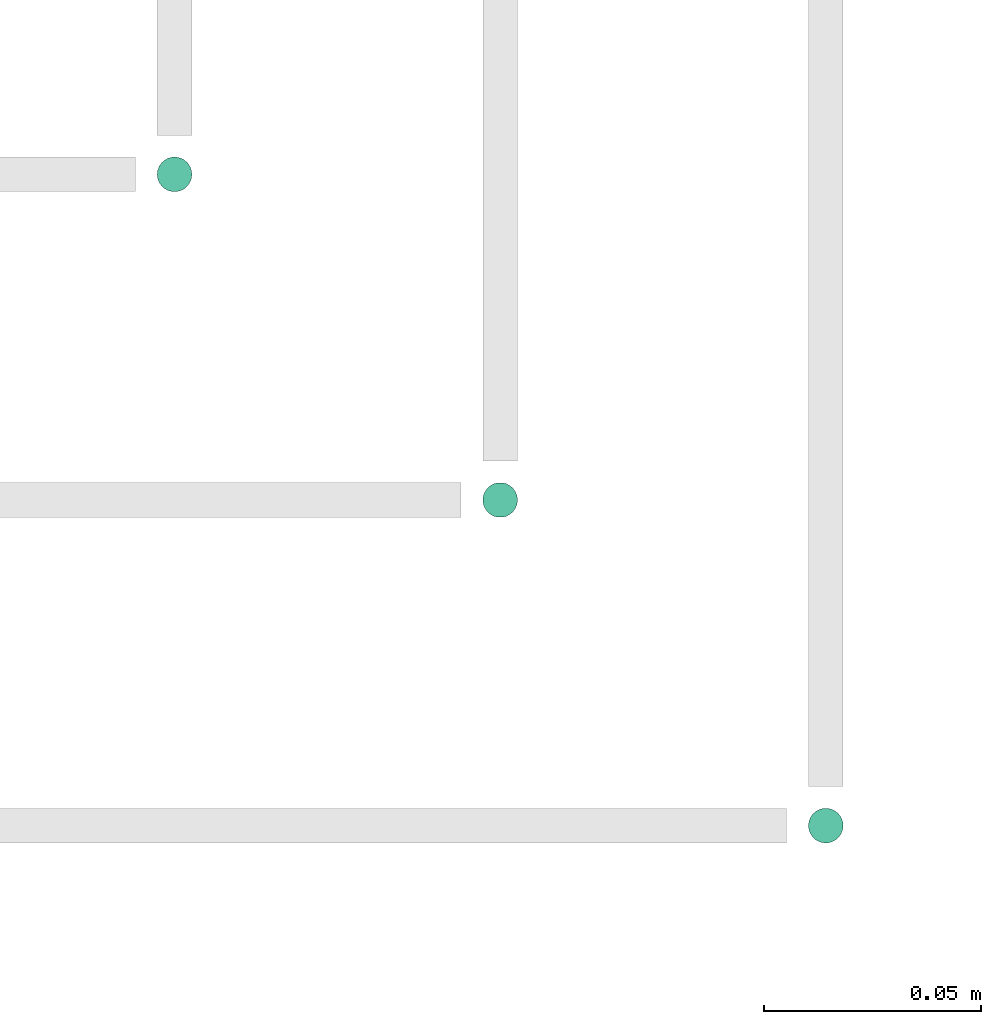
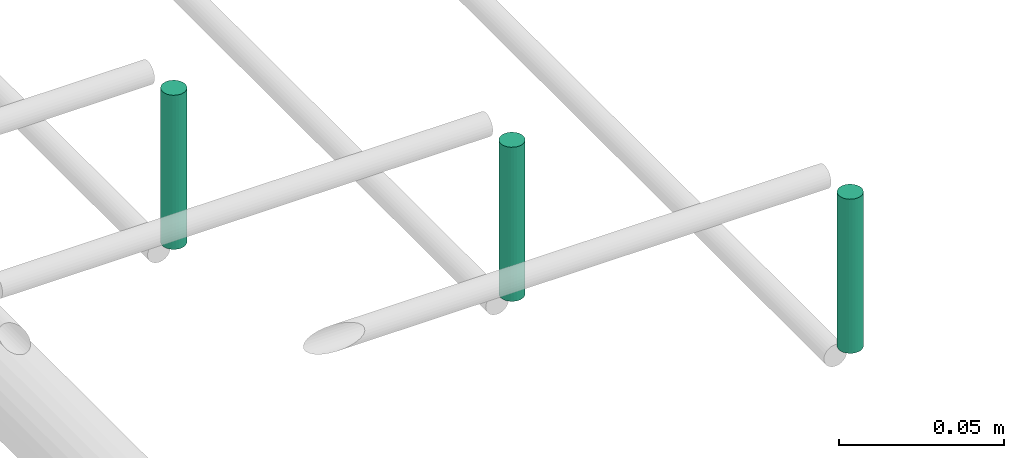
# One storey, part 287 of 331: 3 flow segments.
"""IFC2X3 building model written with IfcOpenShell, lengths in millimetres."""

from ifc_helpers import new_model, entity, si_unit, converted_unit, derived_unit, direction, frame, frame_2d, origin, origin_2d_with_axis, place, context, subcontext, project, spatial, circle, extrude, type_object, element, save


model = new_model("IFC2X3")

# Units and contexts
model_context = context("Model", 3, precision=0.01, world=origin(), true_north=direction((6.12303176911189e-17, 1.0)))
body_context = subcontext(model_context, "Body", "Model", "MODEL_VIEW")
ifc_project = project(units=[si_unit("LENGTHUNIT", "METRE", prefix="MILLI"), si_unit("AREAUNIT", "SQUARE_METRE"), si_unit("VOLUMEUNIT", "CUBIC_METRE"), converted_unit("PLANEANGLEUNIT", "DEGREE", entity("IfcRatioMeasure", 0.0174532925199433), si_unit("PLANEANGLEUNIT", "RADIAN"), dimensions=[0, 0, 0, 0, 0, 0, 0]), si_unit("MASSUNIT", "GRAM", prefix="KILO"), derived_unit("MASSDENSITYUNIT", [(si_unit("MASSUNIT", "GRAM", prefix="KILO"), 1), (si_unit("LENGTHUNIT", "METRE"), -3)]), derived_unit("MOMENTOFINERTIAUNIT", [(si_unit("LENGTHUNIT", "METRE"), 4)]), si_unit("TIMEUNIT", "SECOND"), si_unit("FREQUENCYUNIT", "HERTZ"), si_unit("THERMODYNAMICTEMPERATUREUNIT", "DEGREE_CELSIUS"), derived_unit("THERMALTRANSMITTANCEUNIT", [(si_unit("MASSUNIT", "GRAM", prefix="KILO"), 1), (si_unit("THERMODYNAMICTEMPERATUREUNIT", "KELVIN"), -1), (si_unit("TIMEUNIT", "SECOND"), -3)]), derived_unit("VOLUMETRICFLOWRATEUNIT", [(si_unit("LENGTHUNIT", "METRE"), 3), (si_unit("TIMEUNIT", "SECOND"), -1)]), derived_unit("MASSFLOWRATEUNIT", [(si_unit("MASSUNIT", "GRAM", prefix="KILO"), 1), (si_unit("TIMEUNIT", "SECOND"), -1)]), derived_unit("ROTATIONALFREQUENCYUNIT", [(si_unit("TIMEUNIT", "SECOND"), -1)]), si_unit("ELECTRICCURRENTUNIT", "AMPERE"), si_unit("ELECTRICVOLTAGEUNIT", "VOLT"), si_unit("POWERUNIT", "WATT"), si_unit("FORCEUNIT", "NEWTON", prefix="KILO"), si_unit("ILLUMINANCEUNIT", "LUX"), si_unit("LUMINOUSFLUXUNIT", "LUMEN"), si_unit("LUMINOUSINTENSITYUNIT", "CANDELA"), derived_unit("USERDEFINED", [(si_unit("MASSUNIT", "GRAM", prefix="KILO"), -1), (si_unit("LENGTHUNIT", "METRE"), -2), (si_unit("TIMEUNIT", "SECOND"), 3), (si_unit("LUMINOUSFLUXUNIT", "LUMEN"), 1)]), derived_unit("LINEARVELOCITYUNIT", [(si_unit("LENGTHUNIT", "METRE"), 1), (si_unit("TIMEUNIT", "SECOND"), -1)]), si_unit("PRESSUREUNIT", "PASCAL"), derived_unit("USERDEFINED", [(si_unit("LENGTHUNIT", "METRE"), -2), (si_unit("MASSUNIT", "GRAM", prefix="KILO"), 1), (si_unit("TIMEUNIT", "SECOND"), -2)]), derived_unit("LINEARFORCEUNIT", [(si_unit("MASSUNIT", "GRAM", prefix="KILO"), 1), (si_unit("LENGTHUNIT", "METRE"), 1), (si_unit("TIMEUNIT", "SECOND"), -2), (si_unit("LENGTHUNIT", "METRE"), -1)]), derived_unit("PLANARFORCEUNIT", [(si_unit("MASSUNIT", "GRAM", prefix="KILO"), 1), (si_unit("LENGTHUNIT", "METRE"), 1), (si_unit("TIMEUNIT", "SECOND"), -2), (si_unit("LENGTHUNIT", "METRE"), -2)])], contexts=[model_context])

# Site, building, storey
site_placement = place(None, frame((0.0, -0.00077364408347762, 0.0)))
site = spatial("IfcSite", under=ifc_project, at=site_placement, CompositionType="ELEMENT")
building_placement = place(site_placement, origin())
building = spatial("IfcBuilding", under=site, at=building_placement, CompositionType="ELEMENT")
storey_placement = place(building_placement, origin())
storey = spatial("IfcBuildingStorey", under=building, at=storey_placement, CompositionType="ELEMENT", Elevation=0.0)

# Flow segments
pipe_segment_type = type_object("IfcPipeSegmentType", PredefinedType="NOTDEFINED")
flow_segment_1_placement = place(building_placement, frame((64393.9020185356, 319.404727764273, 2859.0)))
element("IfcFlowSegment", 1, at=flow_segment_1_placement, inside=storey, type_object=pipe_segment_type, context=body_context, shape_type="SweptSolid", body=[
    extrude(circle(Radius=4.0, at=origin_2d_with_axis()), frame((5.59527223591499, 5.59527223591594, 0.0), z_axis=(0.0, 0.0, 1.0), x_axis=(-1.0, 0.0, 0.0)), (0.0, 0.0, 1.0), 57.0000000000076),
])
flow_segment_2_placement = place(building_placement, frame((64468.9020185356, 244.404727764278, 2859.0)))
element("IfcFlowSegment", 2, at=flow_segment_2_placement, inside=storey, type_object=pipe_segment_type, context=body_context, shape_type="SweptSolid", body=[
    extrude(circle(Radius=4.0, at=frame_2d((0.0, -3.38395977905748e-14), x_axis=(1.0, 0.0))), frame((5.59527223591499, 5.59527223591597, 0.0), z_axis=(0.0, 0.0, 1.0), x_axis=(-1.0, 0.0, 0.0)), (0.0, 0.0, 1.0), 57.0000000000184),
])
flow_segment_3_placement = place(building_placement, frame((64543.9020185356, 169.404727764275, 2859.0)))
element("IfcFlowSegment", 3, at=flow_segment_3_placement, inside=storey, type_object=pipe_segment_type, context=body_context, shape_type="SweptSolid", body=[
    extrude(circle(Radius=4.0, at=origin_2d_with_axis()), frame((5.59527223591499, 5.59527223591601, 0.0), z_axis=(0.0, 0.0, 1.0), x_axis=(-1.0, 0.0, 0.0)), (0.0, 0.0, 1.0), 57.000000000019),
])

save(model, "model.ifc")
